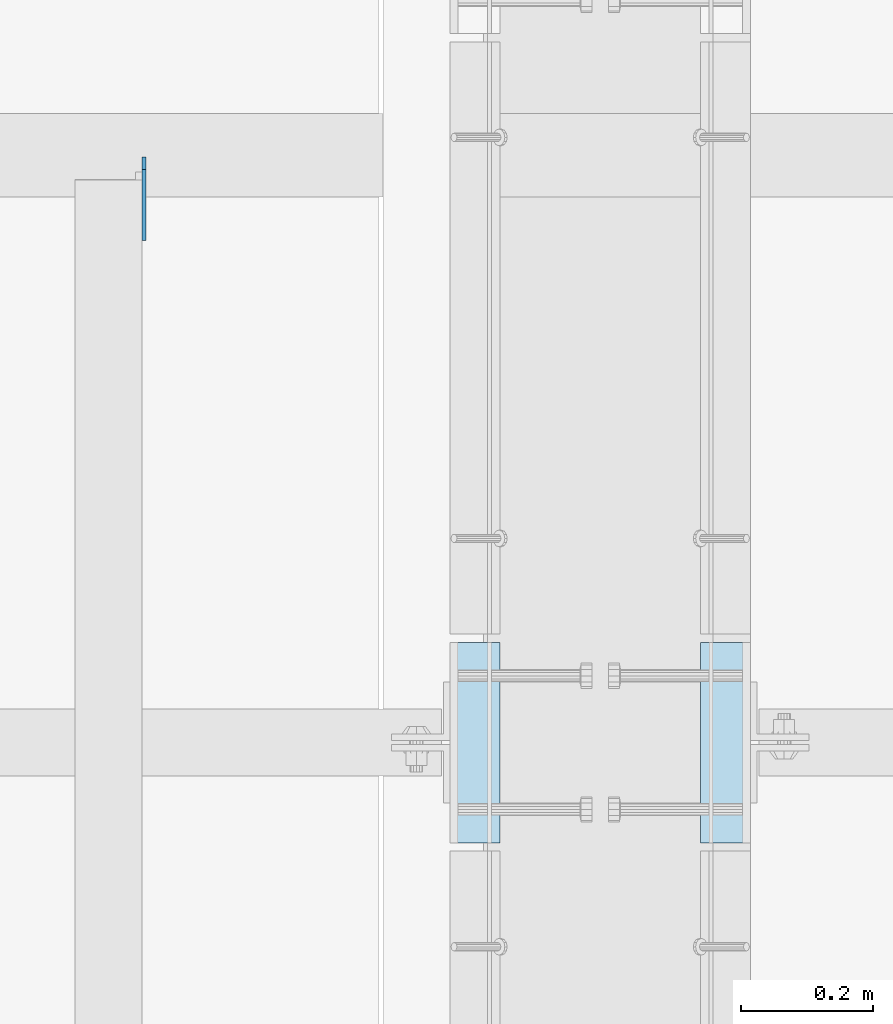
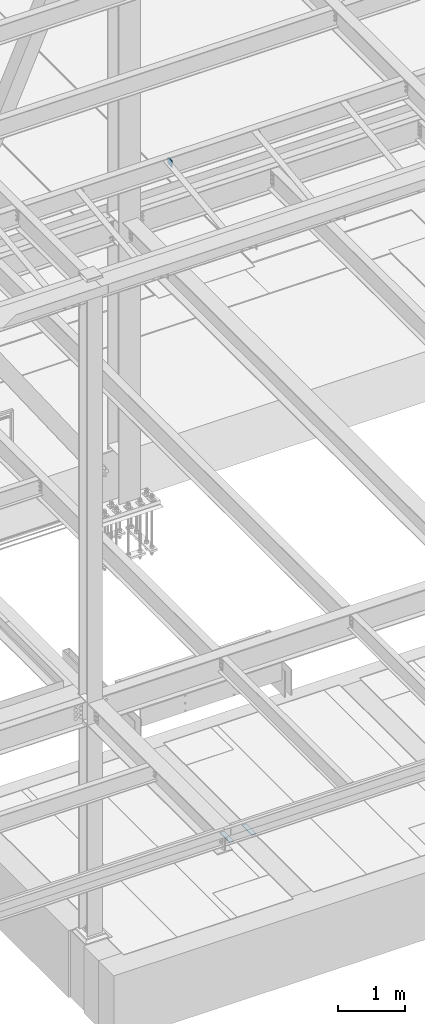
# One storey, part 3117 of 3843: 3 plates, 3 elements without a shape of their own.
"""IFC2X3 building model written with IfcOpenShell, lengths in millimetres."""

from ifc_helpers import new_model, si_unit, frame, origin_with_axes, place, context, subcontext, project, spatial, faceted_brep, material, type_object, element, aggregate, save


model = new_model("IFC2X3")

# Units and contexts
model_context = context("Model", 3, precision=1e-05, world=origin_with_axes())
body_context = subcontext(model_context, "Body", "Model", "MODEL_VIEW")
ifc_project = project(units=[si_unit("LENGTHUNIT", "METRE", prefix="MILLI"), si_unit("AREAUNIT", "SQUARE_METRE"), si_unit("VOLUMEUNIT", "CUBIC_METRE"), si_unit("MASSUNIT", "GRAM", prefix="KILO"), si_unit("TIMEUNIT", "SECOND"), si_unit("PLANEANGLEUNIT", "RADIAN"), si_unit("SOLIDANGLEUNIT", "STERADIAN"), si_unit("THERMODYNAMICTEMPERATUREUNIT", "DEGREE_CELSIUS"), si_unit("LUMINOUSINTENSITYUNIT", "LUMEN")], contexts=[model_context])

# Site, building, storey
site_placement = place(None, origin_with_axes())
site = spatial("IfcSite", under=ifc_project, at=site_placement, CompositionType="ELEMENT")
building_placement = place(site_placement, origin_with_axes())
building = spatial("IfcBuilding", under=site, at=building_placement, Name="Undefined", CompositionType="ELEMENT")
storey_placement = place(building_placement, origin_with_axes())
storey = spatial("IfcBuildingStorey", under=building, at=storey_placement, Name="Undefined", CompositionType="ELEMENT", Elevation=0.0)

# Assembly, plate
assembly_1_placement = place(storey_placement, origin_with_axes())
assembly_1 = element("IfcElementAssembly", 1, at=assembly_1_placement, inside=storey, Name="EMBED PLATE", AssemblyPlace="NOTDEFINED", PredefinedType="RIGID_FRAME")
ifc_material_1 = material(Name="STEEL/A36")
plate_type_1 = type_object("IfcPlateType", PredefinedType="NOTDEFINED")
plate_1_placement = place(assembly_1_placement, frame((58953.3999969482, 16076.6125, 30426.025), z_axis=(0.0, 1.0, 0.0), x_axis=(1.0, 0.0, 0.0)))
plate_1 = element("IfcPlate", 2, at=plate_1_placement, type_object=plate_type_1, material=ifc_material_1, Name="PLATE", context=body_context, shape_type="Brep", body=[
    faceted_brep([(0.0, -3.17499999999927, 0.0), (0.0, -3.17499999999927, 304.800000000003), (0.0, 3.17499999999927, 304.800000000003), (0.0, 3.17499999999927, 0.0), (76.1999999999971, -3.17499999999927, 304.799999999996), (76.1999999999971, 3.17499999999927, 304.799999999996), (76.1999999999971, -3.17499999999927, 0.0), (76.1999999999971, 3.17499999999927, 0.0)], [[[0, 1, 2, 3]], [[1, 4, 5, 2]], [[4, 6, 7, 5]], [[6, 0, 3, 7]], [[5, 7, 3, 2]], [[6, 4, 1, 0]]]),
])
aggregate(assembly_1, [plate_1])

assembly_2_placement = place(storey_placement, origin_with_axes())
assembly_2 = element("IfcElementAssembly", 3, at=assembly_2_placement, inside=storey, Name="EMBED PLATE", AssemblyPlace="NOTDEFINED", PredefinedType="RIGID_FRAME")
plate_2_placement = place(assembly_2_placement, frame((59410.6000030518, 16381.4125, 30426.025), z_axis=(0.0, -1.0, 0.0), x_axis=(-1.0, 0.0, 0.0)))
plate_2 = element("IfcPlate", 4, at=plate_2_placement, type_object=plate_type_1, material=ifc_material_1, Name="PLATE", context=body_context, shape_type="Brep", body=[
    faceted_brep([(0.0, -3.17499999999927, 0.0), (0.0, -3.17499999999927, 304.800000000003), (0.0, 3.17499999999927, 304.800000000003), (0.0, 3.17499999999927, 0.0), (76.1999999999971, -3.17499999999927, 304.799999999996), (76.1999999999971, 3.17499999999927, 304.799999999996), (76.1999999999971, -3.17499999999927, 0.0), (76.1999999999971, 3.17499999999927, 0.0)], [[[0, 1, 2, 3]], [[1, 4, 5, 2]], [[4, 6, 7, 5]], [[6, 0, 3, 7]], [[5, 7, 3, 2]], [[6, 4, 1, 0]]]),
])
aggregate(assembly_2, [plate_2])

assembly_3_placement = place(storey_placement, origin_with_axes())
assembly_3 = element("IfcElementAssembly", 5, at=assembly_3_placement, inside=storey, Name="BEAM", AssemblyPlace="NOTDEFINED", PredefinedType="RIGID_FRAME")
ifc_material_2 = material(Name="STEEL/A572-50")
plate_type_2 = type_object("IfcPlateType", PredefinedType="NOTDEFINED")
plate_3_placement = place(assembly_3_placement, frame((58488.2625, 17118.965, 42330.6875), z_axis=(0.0, 0.0, 1.0), x_axis=(0.0, -1.0, 0.0)))
plate_3 = element("IfcPlate", 6, at=plate_3_placement, type_object=plate_type_2, material=ifc_material_2, Name="PLATE", context=body_context, shape_type="Brep", body=[
    faceted_brep([(0.0, -3.17499999999927, 0.0), (0.0, -3.17500000000291, 107.950000000004), (0.0, 3.17500000000291, 107.950000000004), (0.0, 3.17499999999927, 0.0), (19.0500000000029, -3.17500000000291, 127.0), (19.0500000000029, 3.17500000000291, 127.0), (127.0, -3.17500000000291, 127.0), (127.0, 3.17500000000291, 127.0), (127.0, -3.17500000000291, 0.0), (127.0, 3.17500000000291, 0.0)], [[[0, 1, 2, 3]], [[1, 4, 5, 2]], [[4, 6, 7, 5]], [[6, 8, 9, 7]], [[8, 0, 3, 9]], [[5, 7, 9, 3, 2]], [[8, 6, 4, 1, 0]]]),
])
aggregate(assembly_3, [plate_3])

save(model, "model.ifc")
